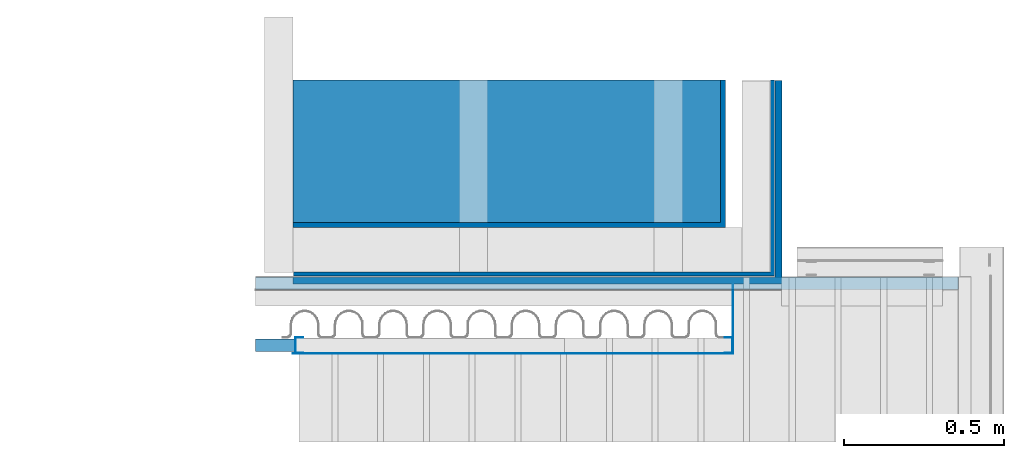
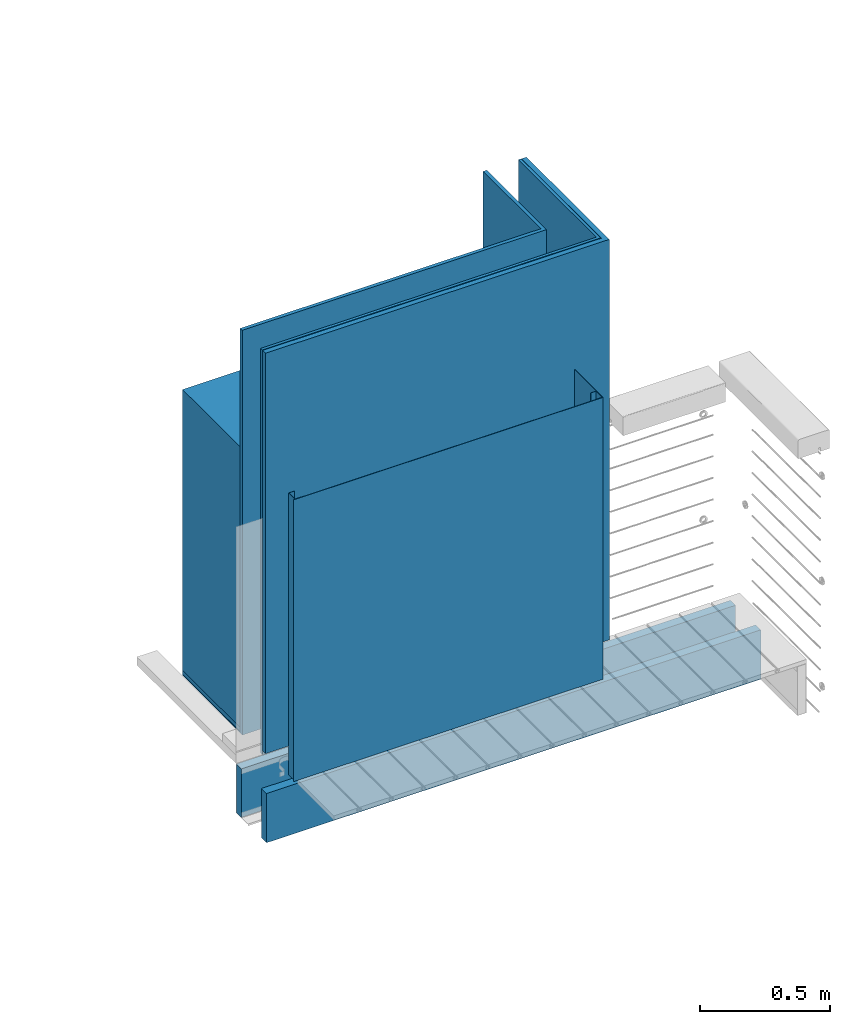
# One storey, part 2 of 33: 12 walls.
"""IFC4 building model written with IfcOpenShell, lengths in feet."""

from ifc_helpers import new_model, entity, si_unit, converted_unit, derived_unit, direction, frame, frame_2d, origin, place, context, subcontext, project, spatial, polyline, rectangle, outline, extrude, material, type_object, element, save


model = new_model("IFC4")

# Units and contexts
model_context = context("Model", 3, precision=0.0001, world=origin(), true_north=direction((6.12303176911189e-17, 1.0)))
body_context = subcontext(model_context, "Body", "Model", "MODEL_VIEW")
ifc_project = project(units=[converted_unit("LENGTHUNIT", "FOOT", entity("IfcRatioMeasure", 0.3048), si_unit("LENGTHUNIT", "METRE"), dimensions=[1, 0, 0, 0, 0, 0, 0]), converted_unit("AREAUNIT", "SQUARE FOOT", entity("IfcRatioMeasure", 0.09290304), si_unit("AREAUNIT", "SQUARE_METRE"), dimensions=[2, 0, 0, 0, 0, 0, 0]), converted_unit("VOLUMEUNIT", "CUBIC FOOT", entity("IfcRatioMeasure", 0.028316846592), si_unit("VOLUMEUNIT", "CUBIC_METRE"), dimensions=[3, 0, 0, 0, 0, 0, 0]), converted_unit("PLANEANGLEUNIT", "DEGREE", entity("IfcRatioMeasure", 0.0174532925199433), si_unit("PLANEANGLEUNIT", "RADIAN"), dimensions=[0, 0, 0, 0, 0, 0, 0]), si_unit("MASSUNIT", "GRAM", prefix="KILO"), derived_unit("MASSDENSITYUNIT", [(si_unit("MASSUNIT", "GRAM", prefix="KILO"), 1), (si_unit("LENGTHUNIT", "METRE"), -3)]), derived_unit("MOMENTOFINERTIAUNIT", [(si_unit("LENGTHUNIT", "METRE"), 4)]), si_unit("TIMEUNIT", "SECOND"), si_unit("FREQUENCYUNIT", "HERTZ"), si_unit("THERMODYNAMICTEMPERATUREUNIT", "DEGREE_CELSIUS"), derived_unit("THERMALTRANSMITTANCEUNIT", [(si_unit("MASSUNIT", "GRAM", prefix="KILO"), 1), (si_unit("THERMODYNAMICTEMPERATUREUNIT", "KELVIN"), -1), (si_unit("TIMEUNIT", "SECOND"), -3)]), derived_unit("VOLUMETRICFLOWRATEUNIT", [(si_unit("LENGTHUNIT", "METRE"), 3), (si_unit("TIMEUNIT", "SECOND"), -1)]), si_unit("ELECTRICCURRENTUNIT", "AMPERE"), si_unit("ELECTRICVOLTAGEUNIT", "VOLT"), si_unit("POWERUNIT", "WATT"), si_unit("FORCEUNIT", "NEWTON"), si_unit("ILLUMINANCEUNIT", "LUX"), si_unit("LUMINOUSFLUXUNIT", "LUMEN"), si_unit("LUMINOUSINTENSITYUNIT", "CANDELA"), derived_unit("USERDEFINED", [(si_unit("MASSUNIT", "GRAM", prefix="KILO"), -1), (si_unit("LENGTHUNIT", "METRE"), -2), (si_unit("TIMEUNIT", "SECOND"), 3), (si_unit("LUMINOUSFLUXUNIT", "LUMEN"), 1)]), derived_unit("LINEARVELOCITYUNIT", [(si_unit("LENGTHUNIT", "METRE"), 1), (si_unit("TIMEUNIT", "SECOND"), -1)]), si_unit("PRESSUREUNIT", "PASCAL"), derived_unit("USERDEFINED", [(si_unit("LENGTHUNIT", "METRE"), -2), (si_unit("MASSUNIT", "GRAM", prefix="KILO"), 1), (si_unit("TIMEUNIT", "SECOND"), -2)]), derived_unit("LINEARFORCEUNIT", [(si_unit("MASSUNIT", "GRAM", prefix="KILO"), 1), (si_unit("LENGTHUNIT", "METRE"), 1), (si_unit("TIMEUNIT", "SECOND"), -2), (si_unit("LENGTHUNIT", "METRE"), -1)]), derived_unit("PLANARFORCEUNIT", [(si_unit("MASSUNIT", "GRAM", prefix="KILO"), 1), (si_unit("LENGTHUNIT", "METRE"), 1), (si_unit("TIMEUNIT", "SECOND"), -2), (si_unit("LENGTHUNIT", "METRE"), -2)])], contexts=[model_context])

# Site, building, storey
site_placement = place(None, origin())
site = spatial("IfcSite", under=ifc_project, at=site_placement, CompositionType="ELEMENT")
building_placement = place(site_placement, origin())
building = spatial("IfcBuilding", under=site, at=building_placement, CompositionType="ELEMENT")
storey_placement = place(building_placement, frame((0.0, 0.0, 10.0)))
storey = spatial("IfcBuildingStorey", under=building, at=storey_placement, Name="2ND FLOOR", CompositionType="ELEMENT", Elevation=10.0000000000002)

# Walls
ifc_material_1 = material(Name="2X10 JOISTS", Category="Materials")
wall_type_1 = type_object("IfcWallType", Name="Generic Models 739:Generic Models 1", PredefinedType="NOTDEFINED", material=ifc_material_1)
wall_1_placement = place(storey_placement, frame((1486.94745796881, 4.61101311890807, -0.0707822117239161)))
element("IfcWall", 1, at=wall_1_placement, inside=storey, type_object=wall_type_1, material=ifc_material_1, Name="Generic Models 739:Generic Models 1", ObjectType="Generic Models 739:Generic Models 1", PredefinedType="NOTDEFINED", context=body_context, shape_type="SweptSolid", body=[
    extrude(rectangle(XDim=0.128187710791988, YDim=7.21897723011125, at=frame_2d((4.44089209850063e-16, 0.0), x_axis=(1.0, 0.0))), frame((3.60948861505562, 0.0640938553960115, 0.0), z_axis=(0.0, 0.0, 1.0), x_axis=(0.0, 1.0, 0.0)), (0.0, 0.0, 1.0), 0.74864841903721),
])
ifc_material_2 = material(Category="Materials")
wall_type_2 = type_object("IfcWallType", Name="corrugated metal wall2:corrugated metal wall", PredefinedType="NOTDEFINED", material=ifc_material_2)
wall_2_placement = place(storey_placement, frame((1487.33453969517, 4.75070963493672, 0.677265764873534)))
element("IfcWall", 2, at=wall_2_placement, inside=storey, type_object=wall_type_2, material=ifc_material_2, Name="corrugated metal wall2:corrugated metal wall", ObjectType="corrugated metal wall2:corrugated metal wall", PredefinedType="NOTDEFINED", context=body_context, shape_type="SweptSolid", body=[
    extrude(outline(polyline([(-3.28125, -0.68519963465725), (1.66145833333349, -0.68519963465725), (1.66145833333348, 1.32873260264783), (1.61979166666674, 1.32873260264783), (1.61979166666674, -0.643532967990583), (-3.28125, -0.643532967990583), (-3.28125, -0.68519963465725)])), frame((3.28125, 0.685199634657255, 0.0)), (0.0, 0.0, 1.0), 6.24981756845961),
])
ifc_material_3 = material(Category="Materials")
wall_type_3 = type_object("IfcWallType", Name="corrugated metal wall6:corrugated metal wall", PredefinedType="NOTDEFINED", material=ifc_material_3)
wall_3_placement = place(storey_placement, frame((1487.33128448684, 4.66694018650945, 0.745402157150181)))
element("IfcWall", 3, at=wall_3_placement, inside=storey, type_object=wall_type_3, material=ifc_material_3, Name="corrugated metal wall6:corrugated metal wall", ObjectType="corrugated metal wall6:corrugated metal wall", PredefinedType="NOTDEFINED", context=body_context, shape_type="SweptSolid", body=[
    extrude(outline(polyline([(-3.32338142432263, -0.722448180936268), (1.6981490454948, -0.722448180936268), (1.6981490454948, 1.37197969520587), (1.62523237882805, 1.37197969520587), (1.62523237882806, -0.649531514269601), (-3.32338142432263, -0.649531514269601), (-3.32338142432263, -0.722448180936268)])), frame((3.32338142432263, 0.722448180936273, 0.0)), (0.0, 0.0, 1.0), 6.18168117618296),
])
ifc_material_4 = material(Category="Materials")
wall_type_4 = type_object("IfcWallType", Name="corrugated metal wall9:corrugated metal wall", PredefinedType="NOTDEFINED", material=ifc_material_4)
wall_4_placement = place(storey_placement, frame((1487.33128448684, 5.25153703402543, 0.677265764873534)))
element("IfcWall", 4, at=wall_4_placement, inside=storey, type_object=wall_type_4, material=ifc_material_4, Name="corrugated metal wall9:corrugated metal wall", ObjectType="corrugated metal wall9:corrugated metal wall", PredefinedType="NOTDEFINED", context=body_context, shape_type="SweptSolid", body=[
    extrude(outline(polyline([(-2.94444444444457, -0.52154896628121), (1.49826388888892, -0.52154896628121), (1.49826388888891, 0.991014599229088), (1.44618055555565, 0.991014599229087), (1.44618055555566, -0.469465632947877), (-2.94444444444457, -0.469465632947877), (-2.94444444444457, -0.52154896628121)])), frame((2.94444444444457, 0.521548966281214, 0.0)), (0.0, 0.0, 1.0), 6.24981756845961),
])
ifc_material_5 = material(Name="3/4 HARDWOOD FLOOR", Category="Materials")
wall_type_5 = type_object("IfcWallType", Name="Generic Models 774:Generic Models 1", PredefinedType="NOTDEFINED", material=ifc_material_5)
wall_5_placement = place(storey_placement, frame((1487.33128448684, 5.30362036735876, 0.762341945223504)))
element("IfcWall", 5, at=wall_5_placement, inside=storey, type_object=wall_type_5, material=ifc_material_5, Name="Generic Models 774:Generic Models 1", ObjectType="Generic Models 774:Generic Models 1", PredefinedType="NOTDEFINED", context=body_context, shape_type="SweptSolid", body=[
    extrude(rectangle(XDim=1.46048023217696, YDim=4.39062500000023, at=frame_2d((0.0, 1.13686837721616e-13), x_axis=(1.0, 0.0))), frame((2.19531250000023, 0.730240116088492, 0.0), z_axis=(0.0, 0.0, 1.0), x_axis=(0.0, 1.0, 0.0)), (0.0, 0.0, 1.0), 4.33338703150902),
])
ifc_material_6 = material(Category="Materials")
wall_type_6 = type_object("IfcWallType", Name="Generic Models 775:Generic Models 1", PredefinedType="NOTDEFINED", material=ifc_material_6)
wall_6_placement = place(storey_placement, frame((1487.33128448684, 5.30362036735876, 0.699841945223117)))
element("IfcWall", 6, at=wall_6_placement, inside=storey, type_object=wall_type_6, material=ifc_material_6, Name="Generic Models 775:Generic Models 1", ObjectType="Generic Models 775:Generic Models 1", PredefinedType="NOTDEFINED", context=body_context, shape_type="SweptSolid", body=[
    extrude(rectangle(XDim=1.46048023217696, YDim=4.39062500000023, at=frame_2d((0.0, 1.13686837721616e-13), x_axis=(1.0, 0.0))), frame((2.19531250000023, 0.73024011608849, 0.0), z_axis=(0.0, 0.0, 1.0), x_axis=(0.0, 1.0, 0.0)), (0.0, 0.0, 1.0), 0.0625000000005151),
])
ifc_material_7 = material(Category="Materials")
wall_type_7 = type_object("IfcWallType", Name="Generic Models 776:Generic Models 1", PredefinedType="NOTDEFINED", material=ifc_material_7)
wall_7_placement = place(storey_placement, frame((1487.33128448684, 5.30362036735876, 0.682580040295086)))
element("IfcWall", 7, at=wall_7_placement, inside=storey, type_object=wall_type_7, material=ifc_material_7, Name="Generic Models 776:Generic Models 1", ObjectType="Generic Models 776:Generic Models 1", PredefinedType="NOTDEFINED", context=body_context, shape_type="SweptSolid", body=[
    extrude(rectangle(XDim=1.46048023217696, YDim=4.39062500000023, at=frame_2d((0.0, 1.13686837721616e-13), x_axis=(1.0, 0.0))), frame((2.19531250000023, 0.730240116088489, 0.0), z_axis=(0.0, 0.0, 1.0), x_axis=(0.0, 1.0, 0.0)), (0.0, 0.0, 1.0), 0.0104166666666679),
])
ifc_material_8 = material(Category="Materials")
wall_type_8 = type_object("IfcWallType", Name="Metal stud3:Metal stud", PredefinedType="NOTDEFINED", material=ifc_material_8)
wall_8_placement = place(storey_placement, frame((1491.76423162332, 3.96151946270905, 0.745402156962722), z_axis=(0.0, 0.0, 1.0), x_axis=(0.0, 1.0, 0.0)))
element("IfcWall", 8, at=wall_8_placement, inside=storey, type_object=wall_type_8, material=ifc_material_8, Name="Metal stud3:Metal stud", ObjectType="Metal stud3:Metal stud", PredefinedType="NOTDEFINED", context=body_context, shape_type="SweptSolid", body=[
    extrude(outline(polyline([(-0.04296875, -0.0803265351172247), (0.0403645833334849, -0.0803265351172247), (0.0403645833334849, -0.0751182017838916), (-0.0377604166667425, -0.0751182017838916), (-0.0377604166667425, 0.0759234648829272), (0.0403645833334849, 0.0759234648829272), (0.0403645833334849, 0.0795212720181917), (-0.04296875, 0.0795212720181917), (-0.04296875, -0.0803265351172247)])), frame((0.0795212720181917, -0.0403645833334849, 0.0), z_axis=(0.0, 0.0, 1.0), x_axis=(0.0, 1.0, 0.0)), (0.0, 0.0, 1.0), 4.3503268197698),
])
wall_type_9 = type_object("IfcWallType", Name="Metal stud7:Metal stud", PredefinedType="NOTDEFINED", material=ifc_material_8)
wall_9_placement = place(storey_placement, frame((1487.35364577433, 3.95990893651115, 0.745402157326422), z_axis=(0.0, 0.0, 1.0), x_axis=(0.0, 1.0, 0.0)))
element("IfcWall", 9, at=wall_9_placement, inside=storey, type_object=wall_type_9, material=ifc_material_8, Name="Metal stud7:Metal stud", ObjectType="Metal stud7:Metal stud", PredefinedType="NOTDEFINED", context=body_context, shape_type="SweptSolid", body=[
    extrude(outline(polyline([(-0.0429687500000004, -0.0807291666667049), (0.0403645833334845, -0.0807291666667049), (0.0403645833334845, -0.0755208333333719), (-0.0377604166667429, -0.0755208333333719), (-0.0377604166667421, 0.0755208333334469), (0.0403645833334853, 0.0755208333334474), (0.0403645833334853, 0.0807291666666294), (-0.0429687499999996, 0.080729166666629), (-0.0429687500000004, -0.0807291666667049)])), frame((0.0807291666667052, -0.0429687500004547, 0.0), z_axis=(0.0, 0.0, 1.0), x_axis=(0.0, -1.0, 0.0)), (0.0, 0.0, 1.0), 4.35032681976981),
])
ifc_material_9 = material(Name="2X JOIST UNDER METAL STUDS", Category="Materials")
wall_type_10 = type_object("IfcWallType", Name="Generic Models 754:Generic Models 1", PredefinedType="NOTDEFINED", material=ifc_material_9)
wall_10_placement = place(storey_placement, frame((1486.94745796881, 3.97705091294422, -0.0780795093915945)))
element("IfcWall", 10, at=wall_10_placement, inside=storey, type_object=wall_type_10, material=ifc_material_9, Name="Generic Models 754:Generic Models 1", ObjectType="Generic Models 754:Generic Models 1", PredefinedType="NOTDEFINED", context=body_context, shape_type="SweptSolid", body=[
    extrude(rectangle(XDim=0.128187710791988, YDim=7.21897723011125, at=frame_2d((-6.66133814775094e-16, 0.0), x_axis=(1.0, 0.0))), frame((3.60948861505562, 0.0640938553960129, 0.0), z_axis=(0.0, 0.0, 1.0), x_axis=(0.0, 1.0, 0.0)), (0.0, 0.0, 1.0), 0.760981666541788),
])
ifc_material_10 = material(Name="16 GA. PERFORATED GALV. STEEL PANEL", Category="Materials")
wall_type_11 = type_object("IfcWallType", Name="PERFORATED GALV. STEEL PANEL4:PERFORATED GALV. STEEL PANEL", PredefinedType="NOTDEFINED", material=ifc_material_10)
wall_11_placement = place(storey_placement, frame((1487.33128448684, 3.95465893651114, 0.745402157150121)))
element("IfcWall", 11, at=wall_11_placement, inside=storey, type_object=wall_type_11, material=ifc_material_10, Name="PERFORATED GALV. STEEL PANEL4:PERFORATED GALV. STEEL PANEL", ObjectType="PERFORATED GALV. STEEL PANEL4:PERFORATED GALV. STEEL PANEL", PredefinedType="NOTDEFINED", context=body_context, shape_type="SweptSolid", body=[
    extrude(rectangle(XDim=4.52153046981744, YDim=0.0052500000000042, at=frame_2d((-1.13686837721616e-13, -3.77475828372553e-15), x_axis=(1.0, 0.0))), frame((2.2607652349086, 0.00262500000000676, 0.0), z_axis=(0.0, 0.0, 1.0), x_axis=(-1.0, 0.0, 0.0)), (0.0, 0.0, 1.0), 4.35032681958237),
])
wall_type_12 = type_object("IfcWallType", Name="PERFORATED GALV. STEEL PANEL5:PERFORATED GALV. STEEL PANEL", PredefinedType="NOTDEFINED", material=ifc_material_10)
wall_12_placement = place(storey_placement, frame((1491.84756495666, 3.95626946270905, 0.745402157150179), z_axis=(0.0, 0.0, 1.0), x_axis=(0.0, 1.0, 0.0)))
element("IfcWall", 12, at=wall_12_placement, inside=storey, type_object=wall_type_12, material=ifc_material_10, Name="PERFORATED GALV. STEEL PANEL5:PERFORATED GALV. STEEL PANEL", ObjectType="PERFORATED GALV. STEEL PANEL5:PERFORATED GALV. STEEL PANEL", PredefinedType="NOTDEFINED", context=body_context, shape_type="SweptSolid", body=[
    extrude(rectangle(XDim=0.710670723800404, YDim=0.0052499999999327, at=frame_2d((-4.44089209850063e-16, 1.13686837721616e-13), x_axis=(1.0, 0.0))), frame((0.355335361900202, -0.00262499999985266, 0.0), z_axis=(0.0, 0.0, 1.0), x_axis=(-1.0, 0.0, 0.0)), (0.0, 0.0, 1.0), 4.35032681958235),
])

save(model, "model.ifc")
